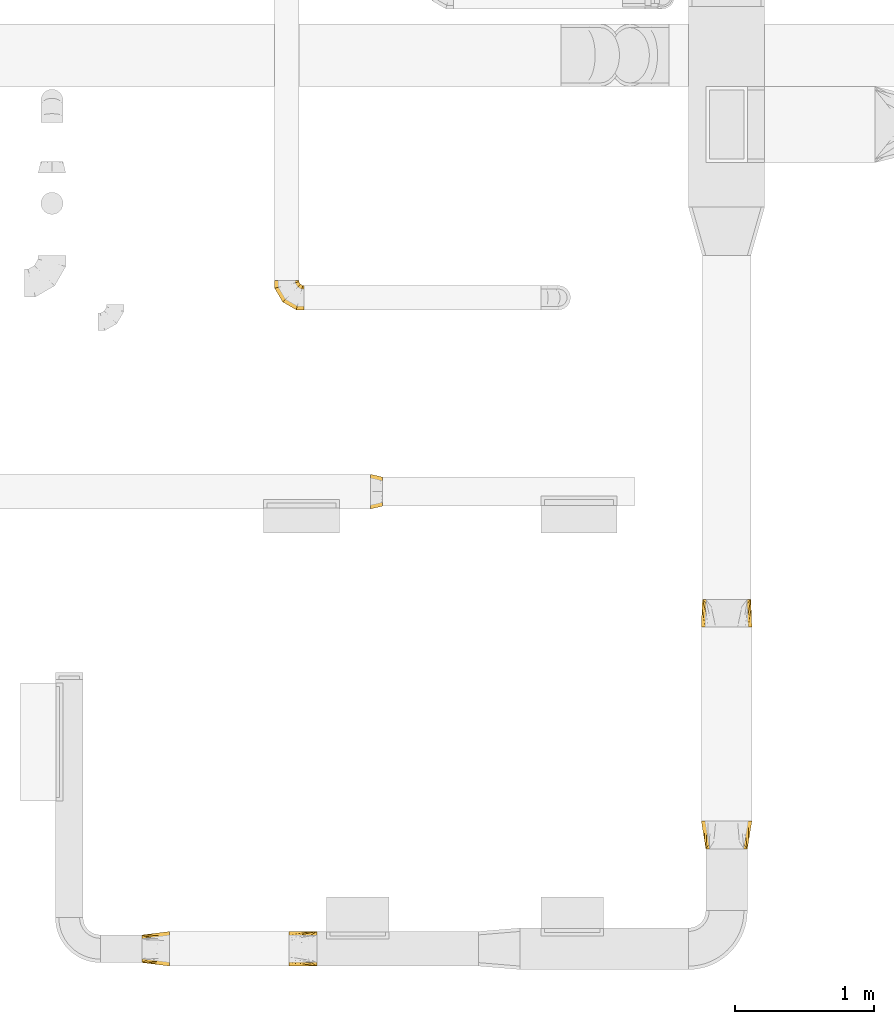
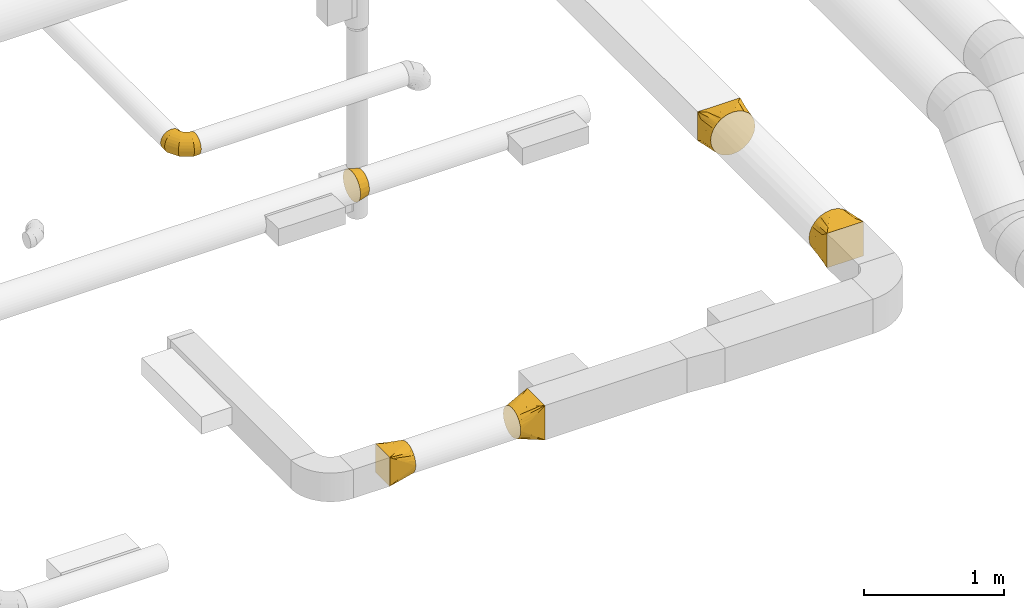
# One storey, part 13 of 97: 6 coverings.
"""IFC2X3 building model written with IfcOpenShell, lengths in millimetres."""

from ifc_helpers import new_model, entity, si_unit, converted_unit, derived_unit, direction, frame, origin, place, context, subcontext, project, spatial, faceted_brep, element, save


model = new_model("IFC2X3")

# Units and contexts
model_context = context("Model", 3, precision=0.01, world=origin(), true_north=direction((6.12303176911189e-17, 1.0)))
body_context = subcontext(model_context, "Body", "Model", "MODEL_VIEW")
ifc_project = project(units=[si_unit("LENGTHUNIT", "METRE", prefix="MILLI"), si_unit("AREAUNIT", "SQUARE_METRE"), si_unit("VOLUMEUNIT", "CUBIC_METRE"), converted_unit("PLANEANGLEUNIT", "DEGREE", entity("IfcRatioMeasure", 0.0174532925199433), si_unit("PLANEANGLEUNIT", "RADIAN"), dimensions=[0, 0, 0, 0, 0, 0, 0]), si_unit("MASSUNIT", "GRAM", prefix="KILO"), derived_unit("MASSDENSITYUNIT", [(si_unit("MASSUNIT", "GRAM", prefix="KILO"), 1), (si_unit("LENGTHUNIT", "METRE"), -3)]), derived_unit("MOMENTOFINERTIAUNIT", [(si_unit("LENGTHUNIT", "METRE"), 4)]), si_unit("TIMEUNIT", "SECOND"), si_unit("FREQUENCYUNIT", "HERTZ"), si_unit("THERMODYNAMICTEMPERATUREUNIT", "DEGREE_CELSIUS"), derived_unit("THERMALTRANSMITTANCEUNIT", [(si_unit("MASSUNIT", "GRAM", prefix="KILO"), 1), (si_unit("THERMODYNAMICTEMPERATUREUNIT", "KELVIN"), -1), (si_unit("TIMEUNIT", "SECOND"), -3)]), derived_unit("VOLUMETRICFLOWRATEUNIT", [(si_unit("LENGTHUNIT", "METRE"), 3), (si_unit("TIMEUNIT", "SECOND"), -1)]), derived_unit("MASSFLOWRATEUNIT", [(si_unit("MASSUNIT", "GRAM", prefix="KILO"), 1), (si_unit("TIMEUNIT", "SECOND"), -1)]), derived_unit("ROTATIONALFREQUENCYUNIT", [(si_unit("TIMEUNIT", "SECOND"), -1)]), si_unit("ELECTRICCURRENTUNIT", "AMPERE"), si_unit("ELECTRICVOLTAGEUNIT", "VOLT"), si_unit("POWERUNIT", "WATT"), si_unit("FORCEUNIT", "NEWTON", prefix="KILO"), si_unit("ILLUMINANCEUNIT", "LUX"), si_unit("LUMINOUSFLUXUNIT", "LUMEN"), si_unit("LUMINOUSINTENSITYUNIT", "CANDELA"), derived_unit("USERDEFINED", [(si_unit("MASSUNIT", "GRAM", prefix="KILO"), -1), (si_unit("LENGTHUNIT", "METRE"), -2), (si_unit("TIMEUNIT", "SECOND"), 3), (si_unit("LUMINOUSFLUXUNIT", "LUMEN"), 1)]), derived_unit("LINEARVELOCITYUNIT", [(si_unit("LENGTHUNIT", "METRE"), 1), (si_unit("TIMEUNIT", "SECOND"), -1)]), si_unit("PRESSUREUNIT", "PASCAL"), derived_unit("USERDEFINED", [(si_unit("LENGTHUNIT", "METRE"), -2), (si_unit("MASSUNIT", "GRAM", prefix="KILO"), 1), (si_unit("TIMEUNIT", "SECOND"), -2)]), derived_unit("LINEARFORCEUNIT", [(si_unit("MASSUNIT", "GRAM", prefix="KILO"), 1), (si_unit("LENGTHUNIT", "METRE"), 1), (si_unit("TIMEUNIT", "SECOND"), -2), (si_unit("LENGTHUNIT", "METRE"), -1)]), derived_unit("PLANARFORCEUNIT", [(si_unit("MASSUNIT", "GRAM", prefix="KILO"), 1), (si_unit("LENGTHUNIT", "METRE"), 1), (si_unit("TIMEUNIT", "SECOND"), -2), (si_unit("LENGTHUNIT", "METRE"), -2)])], contexts=[model_context])

# Site, building, storey
site_placement = place(None, origin())
site = spatial("IfcSite", under=ifc_project, at=site_placement, CompositionType="ELEMENT")
building_placement = place(site_placement, origin())
building = spatial("IfcBuilding", under=site, at=building_placement, CompositionType="ELEMENT")
storey_placement = place(building_placement, frame((0.0, 0.0, -4900.0)))
storey = spatial("IfcBuildingStorey", under=building, at=storey_placement, CompositionType="ELEMENT", Elevation=-4900.0)

# Coverings
covering_1_placement = place(storey_placement, frame((46894.14, 3446.94, 3923.4)))
element("IfcCovering", 1, at=covering_1_placement, inside=storey, PredefinedType="INSULATION", context=body_context, shape_type="Brep", body=[
    faceted_brep([(85.0, 159.04, 226.46), (85.0, 126.6, 231.6), (85.0, 94.15, 226.46), (85.0, 64.88, 211.54), (85.0, 41.65, 188.31), (85.0, 26.73, 159.04), (85.0, 21.6, 126.6), (85.0, 26.73, 94.15), (85.0, 41.65, 64.88), (85.0, 64.88, 41.65), (85.0, 94.15, 26.73), (85.0, 126.6, 21.6), (85.0, 159.04, 26.73), (85.0, 188.31, 41.65), (85.0, 211.54, 64.88), (85.0, 226.46, 94.15), (85.0, 231.6, 126.6), (85.0, 226.46, 159.04), (85.0, 211.54, 188.31), (85.0, 188.31, 211.54), (0.0, 251.6, 126.6), (0.0, 245.48, 87.97), (0.0, 227.72, 53.12), (0.0, 200.07, 25.47), (0.0, 165.22, 7.71), (0.0, 126.6, 1.6), (0.0, 87.97, 7.71), (0.0, 53.12, 25.47), (0.0, 25.47, 53.12), (0.0, 7.71, 87.97), (0.0, 1.6, 126.6), (0.0, 7.71, 165.22), (0.0, 25.47, 200.07), (0.0, 53.12, 227.72), (0.0, 87.97, 245.48), (0.0, 126.6, 251.6), (0.0, 165.22, 245.48), (0.0, 200.07, 227.72), (0.0, 227.72, 200.07), (0.0, 245.48, 165.22)], [[[0, 1, 2, 3, 4, 5, 6, 7, 8, 9, 10, 11, 12, 13, 14, 15, 16, 17, 18, 19]], [[20, 21, 22, 23, 24, 25, 26, 27, 28, 29, 30, 31, 32, 33, 34, 35, 36, 37, 38, 39]], [[10, 9, 27, 26]], [[11, 10, 26, 25]], [[9, 8, 28, 27]], [[28, 8, 7, 29]], [[29, 7, 6, 30]], [[15, 14, 22, 21]], [[16, 15, 21, 20]], [[14, 13, 23, 22]], [[23, 13, 12, 24]], [[24, 12, 11, 25]], [[0, 19, 37, 36]], [[1, 0, 36, 35]], [[19, 18, 38, 37]], [[38, 18, 17, 39]], [[39, 17, 16, 20]], [[5, 4, 32, 31]], [[6, 5, 31, 30]], [[4, 3, 33, 32]], [[33, 3, 2, 34]], [[34, 2, 1, 35]]]),
])
covering_2_placement = place(storey_placement, frame((46200.29, 4884.24, 3650.9)))
element("IfcCovering", 2, at=covering_2_placement, inside=storey, PredefinedType="INSULATION", context=body_context, shape_type="Brep", body=[
    faceted_brep([(214.1, 116.13, 172.31), (214.1, 89.1, 176.6), (214.1, 62.06, 172.31), (214.1, 37.66, 159.88), (214.1, 18.31, 140.53), (214.1, 5.88, 116.13), (214.1, 1.6, 89.1), (214.1, 5.88, 62.06), (214.1, 18.31, 37.66), (214.1, 37.66, 18.31), (214.1, 62.06, 5.88), (214.1, 89.1, 1.6), (214.1, 116.13, 5.88), (214.1, 140.53, 18.31), (214.1, 159.88, 37.66), (214.1, 166.1, 49.86), (214.1, 172.31, 62.06), (214.1, 174.45, 75.58), (214.1, 176.6, 89.1), (214.1, 174.45, 102.61), (214.1, 172.31, 116.13), (214.1, 166.1, 128.33), (214.1, 159.88, 140.53), (214.1, 140.53, 159.88), (13.32, 214.1, 45.35), (4.58, 214.1, 66.45), (1.6, 214.1, 89.1), (4.58, 214.1, 111.74), (13.32, 214.1, 132.85), (27.22, 214.1, 150.97), (45.35, 214.1, 164.87), (66.45, 214.1, 173.61), (89.1, 214.1, 176.6), (111.74, 214.1, 173.61), (132.85, 214.1, 164.87), (150.97, 214.1, 150.97), (164.87, 214.1, 132.85), (173.61, 214.1, 111.74), (176.6, 214.1, 89.1), (173.61, 214.1, 66.45), (164.87, 214.1, 45.35), (150.97, 214.1, 27.22), (132.85, 214.1, 13.32), (111.74, 214.1, 4.58), (89.1, 214.1, 1.6), (66.45, 214.1, 4.58), (45.35, 214.1, 13.32), (27.22, 214.1, 27.22), (1.6, 157.16, 89.1), (4.58, 157.95, 111.74), (13.32, 160.3, 132.85), (27.22, 164.02, 150.97), (45.35, 168.88, 164.87), (66.45, 174.53, 173.61), (89.1, 180.6, 176.6), (111.74, 186.67, 173.61), (132.85, 192.32, 164.87), (150.97, 197.18, 150.97), (164.87, 200.91, 132.85), (173.61, 203.25, 111.74), (176.6, 204.05, 89.1), (173.61, 203.25, 66.45), (164.87, 200.91, 45.35), (150.97, 197.18, 27.22), (111.74, 186.67, 4.58), (89.1, 180.6, 1.6), (132.85, 192.32, 13.32), (66.45, 174.53, 4.58), (45.35, 168.88, 13.32), (27.22, 164.02, 27.22), (13.32, 160.3, 45.35), (4.58, 157.95, 66.45), (58.53, 58.53, 89.1), (60.72, 60.72, 111.74), (67.12, 67.12, 132.85), (77.3, 77.3, 150.97), (90.56, 90.56, 164.87), (106.01, 106.01, 173.61), (122.59, 122.59, 176.6), (139.17, 139.17, 173.61), (154.62, 154.62, 164.87), (167.88, 167.88, 150.97), (178.06, 178.06, 132.85), (184.46, 184.46, 111.74), (186.64, 186.64, 89.1), (184.46, 184.46, 66.45), (178.06, 178.06, 45.35), (167.88, 167.88, 27.22), (139.17, 139.17, 4.58), (122.59, 122.59, 1.6), (154.62, 154.62, 13.32), (106.01, 106.01, 4.58), (90.56, 90.56, 13.32), (77.3, 77.3, 27.22), (67.12, 67.12, 45.35), (60.72, 60.72, 66.45), (157.16, 1.6, 89.1), (157.95, 4.58, 111.74), (160.3, 13.32, 132.85), (164.02, 27.22, 150.97), (168.88, 45.35, 164.87), (174.53, 66.45, 173.61), (180.6, 89.1, 176.6), (186.67, 111.74, 173.61), (192.32, 132.85, 164.87), (197.18, 150.97, 150.97), (200.91, 164.87, 132.85), (203.25, 173.61, 111.74), (203.65, 175.1, 100.42), (204.05, 176.6, 89.1), (203.25, 173.61, 66.45), (200.91, 164.87, 45.35), (203.65, 175.1, 77.77), (197.18, 150.97, 27.22), (186.67, 111.74, 4.58), (180.6, 89.1, 1.6), (192.32, 132.85, 13.32), (174.53, 66.45, 4.58), (168.88, 45.35, 13.32), (164.02, 27.22, 27.22), (160.3, 13.32, 45.35), (157.95, 4.58, 66.45)], [[[0, 1, 2, 3, 4, 5, 6, 7, 8, 9, 10, 11, 12, 13, 14, 15, 16, 17, 18, 19, 20, 21, 22, 23]], [[24, 25, 26, 27, 28, 29, 30, 31, 32, 33, 34, 35, 36, 37, 38, 39, 40, 41, 42, 43, 44, 45, 46, 47]], [[26, 48, 49, 27]], [[27, 49, 50, 28]], [[28, 50, 51, 29]], [[30, 52, 53, 31]], [[31, 53, 54, 32]], [[29, 51, 52, 30]], [[55, 56, 34, 33]], [[54, 55, 33, 32]], [[57, 35, 34, 56]], [[58, 59, 37, 36]], [[58, 36, 35, 57]], [[60, 38, 37, 59]], [[61, 62, 40, 39]], [[60, 61, 39, 38]], [[41, 40, 62, 63]], [[64, 65, 44, 43]], [[66, 64, 43, 42]], [[63, 66, 42, 41]], [[46, 45, 67, 68]], [[47, 46, 68, 69]], [[44, 65, 67, 45]], [[25, 24, 70, 71]], [[26, 25, 71, 48]], [[69, 70, 24, 47]], [[49, 48, 72, 73]], [[50, 49, 73, 74]], [[74, 75, 51, 50]], [[52, 51, 75, 76]], [[53, 52, 76, 77]], [[54, 53, 77, 78]], [[79, 80, 56, 55]], [[78, 79, 55, 54]], [[57, 56, 80, 81]], [[82, 83, 59, 58]], [[81, 82, 58, 57]], [[60, 59, 83, 84]], [[85, 86, 62, 61]], [[84, 85, 61, 60]], [[63, 62, 86, 87]], [[88, 89, 65, 64]], [[90, 88, 64, 66]], [[87, 90, 66, 63]], [[67, 65, 89, 91]], [[68, 67, 91, 92]], [[69, 68, 92, 93]], [[71, 70, 94, 95]], [[48, 71, 95, 72]], [[93, 94, 70, 69]], [[73, 72, 96, 97]], [[74, 73, 97, 98]], [[98, 99, 75, 74]], [[76, 75, 99, 100]], [[77, 76, 100, 101]], [[78, 77, 101, 102]], [[103, 104, 80, 79]], [[102, 103, 79, 78]], [[81, 80, 104, 105]], [[106, 107, 83, 82]], [[105, 106, 82, 81]], [[84, 83, 107, 108, 109]], [[110, 111, 86, 85]], [[85, 84, 109, 112, 110]], [[87, 86, 111, 113]], [[114, 115, 89, 88]], [[116, 114, 88, 90]], [[113, 116, 90, 87]], [[91, 89, 115, 117]], [[92, 91, 117, 118]], [[93, 92, 118, 119]], [[95, 94, 120, 121]], [[72, 95, 121, 96]], [[119, 120, 94, 93]], [[97, 6, 5]], [[98, 5, 4]], [[6, 97, 96]], [[97, 5, 98]], [[4, 99, 98]], [[100, 3, 2]], [[101, 2, 1]], [[99, 3, 100]], [[100, 2, 101]], [[1, 102, 101]], [[3, 99, 4]], [[103, 1, 0]], [[104, 0, 23]], [[103, 102, 1]], [[104, 103, 0]], [[23, 105, 104]], [[21, 20, 107]], [[18, 109, 108]], [[107, 20, 19]], [[106, 105, 22]], [[106, 22, 21]], [[107, 19, 108]], [[21, 107, 106]], [[18, 108, 19]], [[22, 105, 23]], [[110, 17, 16]], [[111, 15, 14]], [[18, 112, 109]], [[18, 17, 112]], [[110, 16, 15]], [[110, 15, 111]], [[14, 113, 111]], [[116, 13, 12]], [[114, 12, 11]], [[116, 113, 13]], [[115, 114, 11]], [[116, 12, 114]], [[17, 110, 112]], [[13, 113, 14]], [[117, 11, 10]], [[118, 10, 9]], [[11, 117, 115]], [[117, 10, 118]], [[9, 119, 118]], [[120, 8, 7]], [[121, 7, 6]], [[119, 8, 120]], [[121, 120, 7]], [[96, 121, 6]], [[8, 119, 9]]]),
])
covering_3_placement = place(storey_placement, frame((49279.5, 2595.77, 4015.9)))
element("IfcCovering", 3, at=covering_3_placement, inside=storey, PredefinedType="INSULATION", context=body_context, shape_type="Brep", body=[
    faceted_brep([(313.14, 0.0, 313.14), (294.24, 0.0, 327.64), (275.35, 0.0, 342.14), (253.34, 0.0, 351.26), (231.33, 0.0, 360.38), (216.46, 0.0, 362.33), (201.59, 0.0, 364.29), (184.1, 0.0, 366.6), (166.6, 0.0, 364.29), (151.73, 0.0, 362.33), (136.86, 0.0, 360.38), (114.85, 0.0, 351.26), (92.85, 0.0, 342.14), (73.95, 0.0, 327.64), (55.05, 0.0, 313.14), (40.55, 0.0, 294.24), (26.05, 0.0, 275.35), (16.93, 0.0, 253.34), (7.81, 0.0, 231.33), (5.86, 0.0, 216.46), (3.9, 0.0, 201.59), (1.6, 0.0, 184.1), (3.9, 0.0, 166.6), (5.86, 0.0, 151.73), (7.81, 0.0, 136.86), (16.93, 0.0, 114.85), (26.05, 0.0, 92.85), (40.55, 0.0, 73.95), (55.05, 0.0, 55.05), (73.95, 0.0, 40.55), (92.85, 0.0, 26.05), (114.85, 0.0, 16.93), (136.86, 0.0, 7.81), (151.73, 0.0, 5.86), (166.6, 0.0, 3.9), (184.1, 0.0, 1.6), (201.59, 0.0, 3.9), (216.46, 0.0, 5.86), (231.33, 0.0, 7.81), (253.34, 0.0, 16.93), (275.35, 0.0, 26.05), (294.24, 0.0, 40.55), (313.14, 0.0, 55.05), (327.64, 0.0, 73.95), (342.14, 0.0, 92.85), (351.26, 0.0, 114.85), (360.38, 0.0, 136.86), (362.33, 0.0, 151.73), (364.29, 0.0, 166.6), (366.6, 0.0, 184.1), (364.29, 0.0, 201.59), (362.33, 0.0, 216.46), (360.38, 0.0, 231.33), (351.26, 0.0, 253.34), (342.14, 0.0, 275.35), (327.64, 0.0, 294.24), (359.1, 200.0, 309.1), (359.1, 200.0, 59.1), (9.1, 200.0, 59.1), (9.1, 200.0, 309.1), (247.02, 71.91, 22.27), (268.0, 95.89, 29.16), (290.77, 121.91, 36.65), (332.1, 100.0, 53.28), (336.32, 173.97, 51.61), (361.05, 147.94, 91.63), (360.07, 173.97, 75.36), (362.02, 121.91, 107.9), (363.0, 95.89, 124.17), (363.9, 71.91, 139.15), (205.07, 23.97, 8.49), (226.05, 47.94, 15.38), (364.8, 47.94, 154.13), (365.7, 23.97, 169.11), (313.55, 147.94, 44.13), (360.07, 173.97, 292.83), (361.05, 147.94, 276.56), (362.02, 121.91, 260.29), (363.0, 95.89, 244.02), (363.9, 71.91, 229.04), (364.8, 47.94, 214.06), (365.7, 23.97, 199.08), (339.91, 100.0, 307.1), (313.55, 147.94, 324.06), (336.32, 173.97, 316.58), (290.77, 121.91, 331.54), (268.0, 95.89, 339.03), (247.02, 71.91, 345.92), (226.05, 47.94, 352.81), (205.07, 23.97, 359.7), (31.87, 173.97, 316.58), (54.65, 147.94, 324.06), (77.42, 121.91, 331.54), (100.2, 95.89, 339.03), (121.17, 71.91, 345.92), (142.15, 47.94, 352.81), (163.12, 23.97, 359.7), (36.1, 100.0, 314.91), (7.14, 147.94, 276.56), (8.12, 173.97, 292.83), (6.17, 121.91, 260.29), (5.19, 95.89, 244.02), (4.29, 71.91, 229.04), (3.39, 47.94, 214.06), (2.49, 23.97, 199.08), (8.12, 173.97, 75.36), (7.14, 147.94, 91.63), (6.17, 121.91, 107.9), (5.19, 95.89, 124.17), (4.29, 71.91, 139.15), (3.39, 47.94, 154.13), (2.49, 23.97, 169.11), (28.28, 100.0, 61.1), (54.65, 147.94, 44.13), (31.87, 173.97, 51.61), (77.42, 121.91, 36.65), (100.2, 95.89, 29.16), (121.17, 71.91, 22.27), (142.15, 47.94, 15.38), (163.12, 23.97, 8.49)], [[[0, 1, 2, 3, 4, 5, 6, 7, 8, 9, 10, 11, 12, 13, 14, 15, 16, 17, 18, 19, 20, 21, 22, 23, 24, 25, 26, 27, 28, 29, 30, 31, 32, 33, 34, 35, 36, 37, 38, 39, 40, 41, 42, 43, 44, 45, 46, 47, 48, 49, 50, 51, 52, 53, 54, 55]], [[56, 57, 58, 59]], [[60, 61, 62, 39]], [[63, 41, 64]], [[43, 42, 63]], [[38, 60, 39]], [[39, 62, 40]], [[65, 44, 43]], [[43, 63, 66]], [[45, 67, 68, 69]], [[70, 71, 60, 38, 37, 36, 35]], [[47, 46, 69, 72, 73, 49, 48]], [[45, 44, 67]], [[45, 69, 46]], [[44, 65, 67]], [[41, 74, 64]], [[41, 40, 74]], [[57, 63, 64]], [[41, 63, 42]], [[43, 66, 65]], [[63, 57, 66]], [[62, 74, 40]], [[57, 56, 75, 76, 77, 78, 79, 80, 81, 49, 73, 72, 69, 68, 67, 65, 66]], [[79, 78, 77, 53]], [[82, 55, 75]], [[1, 0, 82]], [[52, 79, 53]], [[53, 77, 54]], [[83, 2, 1]], [[1, 82, 84]], [[3, 85, 86, 87]], [[81, 80, 79, 52, 51, 50, 49]], [[5, 4, 87, 88, 89, 7, 6]], [[3, 2, 85]], [[3, 87, 4]], [[2, 83, 85]], [[55, 76, 75]], [[55, 54, 76]], [[56, 82, 75]], [[55, 82, 0]], [[1, 84, 83]], [[82, 56, 84]], [[77, 76, 54]], [[56, 59, 90, 91, 92, 93, 94, 95, 96, 7, 89, 88, 87, 86, 85, 83, 84]], [[94, 93, 92, 11]], [[97, 13, 90]], [[15, 14, 97]], [[10, 94, 11]], [[11, 92, 12]], [[98, 16, 15]], [[15, 97, 99]], [[17, 100, 101, 102]], [[96, 95, 94, 10, 9, 8, 7]], [[19, 18, 102, 103, 104, 21, 20]], [[17, 16, 100]], [[17, 102, 18]], [[16, 98, 100]], [[13, 91, 90]], [[13, 12, 91]], [[59, 97, 90]], [[13, 97, 14]], [[15, 99, 98]], [[97, 59, 99]], [[92, 91, 12]], [[59, 58, 105, 106, 107, 108, 109, 110, 111, 21, 104, 103, 102, 101, 100, 98, 99]], [[109, 108, 107, 25]], [[112, 27, 105]], [[29, 28, 112]], [[24, 109, 25]], [[25, 107, 26]], [[113, 30, 29]], [[29, 112, 114]], [[31, 115, 116, 117]], [[111, 110, 109, 24, 23, 22, 21]], [[33, 32, 117, 118, 119, 35, 34]], [[31, 30, 115]], [[31, 117, 32]], [[30, 113, 115]], [[27, 106, 105]], [[27, 26, 106]], [[58, 112, 105]], [[27, 112, 28]], [[29, 114, 113]], [[112, 58, 114]], [[107, 106, 26]], [[58, 57, 64, 74, 62, 61, 60, 71, 70, 35, 119, 118, 117, 116, 115, 113, 114]]]),
])
covering_4_placement = place(storey_placement, frame((49279.5, 995.38, 4015.9)))
element("IfcCovering", 4, at=covering_4_placement, inside=storey, PredefinedType="INSULATION", context=body_context, shape_type="Brep", body=[
    faceted_brep([(55.05, 200.0, 313.14), (73.95, 200.0, 327.64), (92.85, 200.0, 342.14), (114.85, 200.0, 351.26), (136.86, 200.0, 360.38), (151.73, 200.0, 362.33), (166.6, 200.0, 364.29), (184.1, 200.0, 366.6), (201.59, 200.0, 364.29), (216.46, 200.0, 362.33), (231.33, 200.0, 360.38), (253.34, 200.0, 351.26), (275.35, 200.0, 342.14), (294.24, 200.0, 327.64), (313.14, 200.0, 313.14), (327.64, 200.0, 294.24), (342.14, 200.0, 275.35), (351.26, 200.0, 253.34), (360.38, 200.0, 231.33), (362.33, 200.0, 216.46), (364.29, 200.0, 201.59), (366.6, 200.0, 184.1), (364.29, 200.0, 166.6), (362.33, 200.0, 151.73), (360.38, 200.0, 136.86), (351.26, 200.0, 114.85), (342.14, 200.0, 92.85), (327.64, 200.0, 73.95), (313.14, 200.0, 55.05), (294.24, 200.0, 40.55), (275.35, 200.0, 26.05), (253.34, 200.0, 16.93), (231.33, 200.0, 7.81), (216.46, 200.0, 5.86), (201.59, 200.0, 3.9), (184.1, 200.0, 1.6), (166.6, 200.0, 3.9), (151.73, 200.0, 5.86), (136.86, 200.0, 7.81), (114.85, 200.0, 16.93), (92.85, 200.0, 26.05), (73.95, 200.0, 40.55), (55.05, 200.0, 55.05), (40.55, 200.0, 73.95), (26.05, 200.0, 92.85), (16.93, 200.0, 114.85), (7.81, 200.0, 136.86), (5.86, 200.0, 151.73), (3.9, 200.0, 166.6), (1.6, 200.0, 184.1), (3.9, 200.0, 201.59), (5.86, 200.0, 216.46), (7.81, 200.0, 231.33), (16.93, 200.0, 253.34), (26.05, 200.0, 275.35), (40.55, 200.0, 294.24), (34.1, 0.0, 334.1), (34.1, 0.0, 34.1), (334.1, 0.0, 34.1), (334.1, 0.0, 334.1), (130.16, 128.09, 13.28), (112.18, 104.11, 17.18), (92.66, 78.09, 21.41), (48.6, 100.0, 40.78), (53.62, 26.03, 29.87), (25.64, 52.06, 73.14), (29.87, 26.03, 53.62), (21.41, 78.09, 92.66), (17.18, 104.11, 112.18), (13.28, 128.09, 130.16), (166.12, 176.03, 5.49), (148.14, 152.06, 9.39), (9.39, 152.06, 148.14), (5.49, 176.03, 166.12), (73.14, 52.06, 25.64), (29.87, 26.03, 314.57), (25.64, 52.06, 295.05), (21.41, 78.09, 275.53), (17.18, 104.11, 256.01), (13.28, 128.09, 238.03), (9.39, 152.06, 220.05), (5.49, 176.03, 202.07), (40.78, 100.0, 319.6), (73.14, 52.06, 342.55), (53.62, 26.03, 338.32), (92.66, 78.09, 346.78), (112.18, 104.11, 351.01), (130.16, 128.09, 354.91), (148.14, 152.06, 358.8), (166.12, 176.03, 362.7), (314.57, 26.03, 338.32), (295.05, 52.06, 342.55), (275.53, 78.09, 346.78), (256.01, 104.11, 351.01), (238.03, 128.09, 354.91), (220.05, 152.06, 358.8), (202.07, 176.03, 362.7), (319.6, 100.0, 327.41), (342.55, 52.06, 295.05), (338.32, 26.03, 314.57), (346.78, 78.09, 275.53), (351.01, 104.11, 256.01), (354.91, 128.09, 238.03), (358.8, 152.06, 220.05), (362.7, 176.03, 202.07), (338.32, 26.03, 53.62), (342.55, 52.06, 73.14), (346.78, 78.09, 92.66), (351.01, 104.11, 112.18), (354.91, 128.09, 130.16), (358.8, 152.06, 148.14), (362.7, 176.03, 166.12), (327.41, 100.0, 48.6), (295.05, 52.06, 25.64), (314.57, 26.03, 29.87), (275.53, 78.09, 21.41), (256.01, 104.11, 17.18), (238.03, 128.09, 13.28), (220.05, 152.06, 9.39), (202.07, 176.03, 5.49)], [[[0, 1, 2, 3, 4, 5, 6, 7, 8, 9, 10, 11, 12, 13, 14, 15, 16, 17, 18, 19, 20, 21, 22, 23, 24, 25, 26, 27, 28, 29, 30, 31, 32, 33, 34, 35, 36, 37, 38, 39, 40, 41, 42, 43, 44, 45, 46, 47, 48, 49, 50, 51, 52, 53, 54, 55]], [[56, 57, 58, 59]], [[60, 61, 62, 39]], [[63, 41, 64]], [[43, 42, 63]], [[38, 60, 39]], [[39, 62, 40]], [[65, 44, 43]], [[43, 63, 66]], [[45, 67, 68, 69]], [[70, 71, 60, 38, 37, 36, 35]], [[47, 46, 69, 72, 73, 49, 48]], [[45, 44, 67]], [[45, 69, 46]], [[44, 65, 67]], [[41, 74, 64]], [[41, 40, 74]], [[57, 63, 64]], [[41, 63, 42]], [[43, 66, 65]], [[63, 57, 66]], [[62, 74, 40]], [[57, 56, 75, 76, 77, 78, 79, 80, 81, 49, 73, 72, 69, 68, 67, 65, 66]], [[79, 78, 77, 53]], [[82, 55, 75]], [[1, 0, 82]], [[52, 79, 53]], [[53, 77, 54]], [[83, 2, 1]], [[1, 82, 84]], [[3, 85, 86, 87]], [[81, 80, 79, 52, 51, 50, 49]], [[5, 4, 87, 88, 89, 7, 6]], [[3, 2, 85]], [[3, 87, 4]], [[2, 83, 85]], [[55, 76, 75]], [[55, 54, 76]], [[56, 82, 75]], [[55, 82, 0]], [[1, 84, 83]], [[82, 56, 84]], [[77, 76, 54]], [[56, 59, 90, 91, 92, 93, 94, 95, 96, 7, 89, 88, 87, 86, 85, 83, 84]], [[94, 93, 92, 11]], [[97, 13, 90]], [[15, 14, 97]], [[10, 94, 11]], [[11, 92, 12]], [[98, 16, 15]], [[15, 97, 99]], [[17, 100, 101, 102]], [[96, 95, 94, 10, 9, 8, 7]], [[19, 18, 102, 103, 104, 21, 20]], [[17, 16, 100]], [[17, 102, 18]], [[16, 98, 100]], [[13, 91, 90]], [[13, 12, 91]], [[59, 97, 90]], [[13, 97, 14]], [[15, 99, 98]], [[97, 59, 99]], [[92, 91, 12]], [[59, 58, 105, 106, 107, 108, 109, 110, 111, 21, 104, 103, 102, 101, 100, 98, 99]], [[109, 108, 107, 25]], [[112, 27, 105]], [[29, 28, 112]], [[24, 109, 25]], [[25, 107, 26]], [[113, 30, 29]], [[29, 112, 114]], [[31, 115, 116, 117]], [[111, 110, 109, 24, 23, 22, 21]], [[33, 32, 117, 118, 119, 35, 34]], [[31, 30, 115]], [[31, 117, 32]], [[30, 113, 115]], [[27, 106, 105]], [[27, 26, 106]], [[58, 112, 105]], [[27, 112, 28]], [[29, 114, 113]], [[112, 58, 114]], [[107, 106, 26]], [[58, 57, 64, 74, 62, 61, 60, 71, 70, 35, 119, 118, 117, 116, 115, 113, 114]]]),
])
covering_5_placement = place(storey_placement, frame((46306.13, 147.28, 4050.0)))
element("IfcCovering", 5, at=covering_5_placement, inside=storey, PredefinedType="INSULATION", context=body_context, shape_type="Brep", body=[
    faceted_brep([(0.0, 126.6, 275.0), (0.0, 132.56, 274.06), (0.0, 138.52, 273.11), (0.0, 150.44, 271.22), (0.0, 165.22, 268.88), (0.0, 182.65, 260.0), (0.0, 200.07, 251.13), (0.0, 213.9, 237.3), (0.0, 227.72, 223.47), (0.0, 236.6, 206.05), (0.0, 245.48, 188.63), (0.0, 247.82, 173.84), (0.0, 249.71, 161.92), (0.0, 250.65, 155.96), (0.0, 251.6, 150.0), (0.0, 250.65, 144.04), (0.0, 249.71, 138.08), (0.0, 247.82, 126.16), (0.0, 245.48, 111.37), (0.0, 236.6, 93.95), (0.0, 227.72, 76.53), (0.0, 213.9, 62.7), (0.0, 200.07, 48.87), (0.0, 182.65, 40.0), (0.0, 165.22, 31.12), (0.0, 150.44, 28.78), (0.0, 138.52, 26.89), (0.0, 132.56, 25.94), (0.0, 126.6, 25.0), (0.0, 120.63, 25.94), (0.0, 114.67, 26.89), (0.0, 102.75, 28.78), (0.0, 87.97, 31.12), (0.0, 70.55, 40.0), (0.0, 53.12, 48.87), (0.0, 39.3, 62.7), (0.0, 25.47, 76.53), (0.0, 16.59, 93.95), (0.0, 7.71, 111.37), (0.0, 5.37, 126.16), (0.0, 3.48, 138.08), (0.0, 2.54, 144.04), (0.0, 1.6, 150.0), (0.0, 2.54, 155.96), (0.0, 3.48, 161.92), (0.0, 5.37, 173.84), (0.0, 7.71, 188.63), (0.0, 16.59, 206.05), (0.0, 25.47, 223.47), (0.0, 39.3, 237.3), (0.0, 53.12, 251.13), (0.0, 70.55, 260.0), (0.0, 87.97, 268.88), (0.0, 102.75, 271.22), (0.0, 114.67, 273.11), (0.0, 120.63, 274.06), (200.0, 1.6, 300.0), (200.0, 1.6, 0.0), (200.0, 251.6, 0.0), (200.0, 251.6, 300.0), (95.89, 66.67, 13.01), (100.0, 22.66, 28.21), (173.97, 17.86, 3.25), (121.91, 50.4, 9.76), (147.94, 34.13, 6.51), (11.99, 119.1, 23.5), (23.97, 111.61, 22.0), (47.94, 96.63, 19.01), (71.91, 81.65, 16.01), (147.94, 1.6, 39.04), (121.91, 1.6, 58.56), (95.89, 1.6, 78.09), (71.91, 1.6, 96.06), (47.94, 1.6, 114.04), (23.97, 1.6, 132.02), (11.99, 1.6, 141.01), (173.97, 1.6, 19.52), (173.97, 1.6, 280.48), (147.94, 1.6, 260.96), (121.91, 1.6, 241.44), (95.89, 1.6, 221.91), (71.91, 1.6, 203.94), (47.94, 1.6, 185.96), (23.97, 1.6, 167.98), (11.99, 1.6, 158.99), (100.0, 17.31, 266.44), (147.94, 34.13, 293.49), (121.91, 50.4, 290.24), (95.89, 66.67, 286.99), (71.91, 81.65, 283.99), (47.94, 96.63, 280.99), (23.97, 111.61, 278.0), (11.99, 119.1, 276.5), (173.97, 17.86, 296.75), (173.97, 235.33, 296.75), (147.94, 219.06, 293.49), (121.91, 202.79, 290.24), (95.89, 186.52, 286.99), (71.91, 171.54, 283.99), (47.94, 156.56, 280.99), (23.97, 141.58, 278.0), (11.99, 134.09, 276.5), (100.0, 230.53, 271.79), (147.94, 251.6, 260.96), (121.91, 251.6, 241.44), (95.89, 251.6, 221.91), (71.91, 251.6, 203.94), (47.94, 251.6, 185.96), (23.97, 251.6, 167.98), (11.99, 251.6, 158.99), (173.97, 251.6, 280.48), (173.97, 251.6, 19.52), (147.94, 251.6, 39.04), (121.91, 251.6, 58.56), (95.89, 251.6, 78.09), (71.91, 251.6, 96.06), (47.94, 251.6, 114.04), (23.97, 251.6, 132.02), (11.99, 251.6, 141.01), (100.0, 235.88, 33.56), (147.94, 219.06, 6.51), (121.91, 202.79, 9.76), (95.89, 186.52, 13.01), (71.91, 171.54, 16.01), (47.94, 156.56, 19.01), (23.97, 141.58, 22.0), (11.99, 134.09, 23.5), (173.97, 235.33, 3.25)], [[[0, 1, 2, 3, 4, 5, 6, 7, 8, 9, 10, 11, 12, 13, 14, 15, 16, 17, 18, 19, 20, 21, 22, 23, 24, 25, 26, 27, 28, 29, 30, 31, 32, 33, 34, 35, 36, 37, 38, 39, 40, 41, 42, 43, 44, 45, 46, 47, 48, 49, 50, 51, 52, 53, 54, 55]], [[56, 57, 58, 59]], [[60, 33, 32]], [[57, 61, 62]], [[33, 60, 63, 64]], [[65, 66, 67, 68, 60, 32, 31, 30, 29, 28]], [[62, 61, 34]], [[37, 69, 70, 71]], [[64, 34, 33]], [[38, 71, 72, 73, 74, 75, 42, 41, 40, 39]], [[36, 76, 69]], [[71, 38, 37]], [[61, 76, 35]], [[34, 64, 62]], [[76, 36, 35]], [[34, 61, 35]], [[61, 57, 76]], [[69, 37, 36]], [[57, 56, 77, 78, 79, 80, 81, 82, 83, 84, 42, 75, 74, 73, 72, 71, 70, 69, 76]], [[80, 47, 46]], [[56, 85, 77]], [[47, 80, 79, 78]], [[84, 83, 82, 81, 80, 46, 45, 44, 43, 42]], [[77, 85, 48]], [[51, 86, 87, 88]], [[78, 48, 47]], [[52, 88, 89, 90, 91, 92, 0, 55, 54, 53]], [[50, 93, 86]], [[88, 52, 51]], [[85, 93, 49]], [[48, 78, 77]], [[93, 50, 49]], [[48, 85, 49]], [[85, 56, 93]], [[86, 51, 50]], [[56, 59, 94, 95, 96, 97, 98, 99, 100, 101, 0, 92, 91, 90, 89, 88, 87, 86, 93]], [[97, 5, 4]], [[59, 102, 94]], [[5, 97, 96, 95]], [[101, 100, 99, 98, 97, 4, 3, 2, 1, 0]], [[94, 102, 6]], [[9, 103, 104, 105]], [[95, 6, 5]], [[10, 105, 106, 107, 108, 109, 14, 13, 12, 11]], [[8, 110, 103]], [[105, 10, 9]], [[102, 110, 7]], [[6, 95, 94]], [[110, 8, 7]], [[6, 102, 7]], [[102, 59, 110]], [[103, 9, 8]], [[109, 108, 107, 106, 105, 104, 103, 110, 59, 58, 111, 112, 113, 114, 115, 116, 117, 118, 14]], [[114, 19, 18]], [[58, 119, 111]], [[19, 114, 113, 112]], [[118, 117, 116, 115, 114, 18, 17, 16, 15, 14]], [[111, 119, 20]], [[23, 120, 121, 122]], [[112, 20, 19]], [[24, 122, 123, 124, 125, 126, 28, 27, 26, 25]], [[22, 127, 120]], [[122, 24, 23]], [[119, 127, 21]], [[20, 112, 111]], [[127, 22, 21]], [[20, 119, 21]], [[119, 58, 127]], [[120, 23, 22]], [[126, 125, 124, 123, 122, 121, 120, 127, 58, 57, 62, 64, 63, 60, 68, 67, 66, 65, 28]]]),
])
covering_6_placement = place(storey_placement, frame((45243.8, 147.28, 4073.4)))
element("IfcCovering", 6, at=covering_6_placement, inside=storey, PredefinedType="INSULATION", context=body_context, shape_type="Brep", body=[
    faceted_brep([(200.0, 126.6, 251.6), (200.0, 120.63, 250.65), (200.0, 114.67, 249.71), (200.0, 102.75, 247.82), (200.0, 87.97, 245.48), (200.0, 70.55, 236.6), (200.0, 53.12, 227.72), (200.0, 39.3, 213.9), (200.0, 25.47, 200.07), (200.0, 16.59, 182.65), (200.0, 7.71, 165.22), (200.0, 5.37, 150.44), (200.0, 3.48, 138.52), (200.0, 2.54, 132.56), (200.0, 1.6, 126.6), (200.0, 2.54, 120.63), (200.0, 3.48, 114.67), (200.0, 5.37, 102.75), (200.0, 7.71, 87.97), (200.0, 16.59, 70.55), (200.0, 25.47, 53.12), (200.0, 39.3, 39.3), (200.0, 53.12, 25.47), (200.0, 70.55, 16.59), (200.0, 87.97, 7.71), (200.0, 102.75, 5.37), (200.0, 114.67, 3.48), (200.0, 120.63, 2.54), (200.0, 126.6, 1.6), (200.0, 132.56, 2.54), (200.0, 138.52, 3.48), (200.0, 150.44, 5.37), (200.0, 165.22, 7.71), (200.0, 182.65, 16.59), (200.0, 200.07, 25.47), (200.0, 213.9, 39.3), (200.0, 227.72, 53.12), (200.0, 236.6, 70.55), (200.0, 245.48, 87.97), (200.0, 247.82, 102.75), (200.0, 249.71, 114.67), (200.0, 250.65, 120.63), (200.0, 251.6, 126.6), (200.0, 250.65, 132.56), (200.0, 249.71, 138.52), (200.0, 247.82, 150.44), (200.0, 245.48, 165.22), (200.0, 236.6, 182.65), (200.0, 227.72, 200.07), (200.0, 213.9, 213.9), (200.0, 200.07, 227.72), (200.0, 182.65, 236.6), (200.0, 165.22, 245.48), (200.0, 150.44, 247.82), (200.0, 138.52, 249.71), (200.0, 132.56, 250.65), (0.0, 226.6, 251.6), (0.0, 226.6, 1.6), (0.0, 26.6, 1.6), (0.0, 26.6, 251.6), (104.11, 174.54, 1.6), (100.0, 218.03, 17.31), (26.03, 213.58, 1.6), (78.09, 187.55, 1.6), (52.06, 200.57, 1.6), (188.01, 132.59, 1.6), (176.03, 138.58, 1.6), (152.06, 150.57, 1.6), (128.09, 162.55, 1.6), (52.06, 233.1, 34.13), (78.09, 236.36, 50.4), (104.11, 239.61, 66.67), (128.09, 242.61, 81.65), (152.06, 245.6, 96.63), (176.03, 248.6, 111.61), (188.01, 250.1, 119.1), (26.03, 229.85, 17.86), (26.03, 229.85, 235.33), (52.06, 233.1, 219.06), (78.09, 236.36, 202.79), (104.11, 239.61, 186.52), (128.09, 242.61, 171.54), (152.06, 245.6, 156.56), (176.03, 248.6, 141.58), (188.01, 250.1, 134.09), (100.0, 223.38, 230.53), (52.06, 200.57, 251.6), (78.09, 187.55, 251.6), (104.11, 174.54, 251.6), (128.09, 162.55, 251.6), (152.06, 150.57, 251.6), (176.03, 138.58, 251.6), (188.01, 132.59, 251.6), (26.03, 213.58, 251.6), (26.03, 39.61, 251.6), (52.06, 52.62, 251.6), (78.09, 65.64, 251.6), (104.11, 78.65, 251.6), (128.09, 90.64, 251.6), (152.06, 102.62, 251.6), (176.03, 114.61, 251.6), (188.01, 120.6, 251.6), (100.0, 35.16, 235.88), (52.06, 20.09, 219.06), (78.09, 16.83, 202.79), (104.11, 13.58, 186.52), (128.09, 10.58, 171.54), (152.06, 7.59, 156.56), (176.03, 4.59, 141.58), (188.01, 3.09, 134.09), (26.03, 23.34, 235.33), (26.03, 23.34, 17.86), (52.06, 20.09, 34.13), (78.09, 16.83, 50.4), (104.11, 13.58, 66.67), (128.09, 10.58, 81.65), (152.06, 7.59, 96.63), (176.03, 4.59, 111.61), (188.01, 3.09, 119.1), (100.0, 29.81, 22.66), (52.06, 52.62, 1.6), (78.09, 65.64, 1.6), (104.11, 78.65, 1.6), (128.09, 90.64, 1.6), (152.06, 102.62, 1.6), (176.03, 114.61, 1.6), (188.01, 120.6, 1.6), (26.03, 39.61, 1.6)], [[[0, 1, 2, 3, 4, 5, 6, 7, 8, 9, 10, 11, 12, 13, 14, 15, 16, 17, 18, 19, 20, 21, 22, 23, 24, 25, 26, 27, 28, 29, 30, 31, 32, 33, 34, 35, 36, 37, 38, 39, 40, 41, 42, 43, 44, 45, 46, 47, 48, 49, 50, 51, 52, 53, 54, 55]], [[56, 57, 58, 59]], [[60, 33, 32]], [[57, 61, 62]], [[33, 60, 63, 64]], [[65, 66, 67, 68, 60, 32, 31, 30, 29, 28]], [[62, 61, 34]], [[37, 69, 70, 71]], [[64, 34, 33]], [[38, 71, 72, 73, 74, 75, 42, 41, 40, 39]], [[36, 76, 69]], [[71, 38, 37]], [[61, 76, 35]], [[34, 64, 62]], [[76, 36, 35]], [[34, 61, 35]], [[61, 57, 76]], [[69, 37, 36]], [[57, 56, 77, 78, 79, 80, 81, 82, 83, 84, 42, 75, 74, 73, 72, 71, 70, 69, 76]], [[80, 47, 46]], [[56, 85, 77]], [[47, 80, 79, 78]], [[84, 83, 82, 81, 80, 46, 45, 44, 43, 42]], [[77, 85, 48]], [[51, 86, 87, 88]], [[78, 48, 47]], [[52, 88, 89, 90, 91, 92, 0, 55, 54, 53]], [[50, 93, 86]], [[88, 52, 51]], [[85, 93, 49]], [[48, 78, 77]], [[93, 50, 49]], [[48, 85, 49]], [[85, 56, 93]], [[86, 51, 50]], [[56, 59, 94, 95, 96, 97, 98, 99, 100, 101, 0, 92, 91, 90, 89, 88, 87, 86, 93]], [[97, 5, 4]], [[59, 102, 94]], [[5, 97, 96, 95]], [[101, 100, 99, 98, 97, 4, 3, 2, 1, 0]], [[94, 102, 6]], [[9, 103, 104, 105]], [[95, 6, 5]], [[10, 105, 106, 107, 108, 109, 14, 13, 12, 11]], [[8, 110, 103]], [[105, 10, 9]], [[102, 110, 7]], [[6, 95, 94]], [[110, 8, 7]], [[6, 102, 7]], [[102, 59, 110]], [[103, 9, 8]], [[109, 108, 107, 106, 105, 104, 103, 110, 59, 58, 111, 112, 113, 114, 115, 116, 117, 118, 14]], [[114, 19, 18]], [[58, 119, 111]], [[19, 114, 113, 112]], [[118, 117, 116, 115, 114, 18, 17, 16, 15, 14]], [[111, 119, 20]], [[23, 120, 121, 122]], [[112, 20, 19]], [[24, 122, 123, 124, 125, 126, 28, 27, 26, 25]], [[22, 127, 120]], [[122, 24, 23]], [[119, 127, 21]], [[20, 112, 111]], [[127, 22, 21]], [[20, 119, 21]], [[119, 58, 127]], [[120, 23, 22]], [[126, 125, 124, 123, 122, 121, 120, 127, 58, 57, 62, 64, 63, 60, 68, 67, 66, 65, 28]]]),
])

save(model, "model.ifc")
